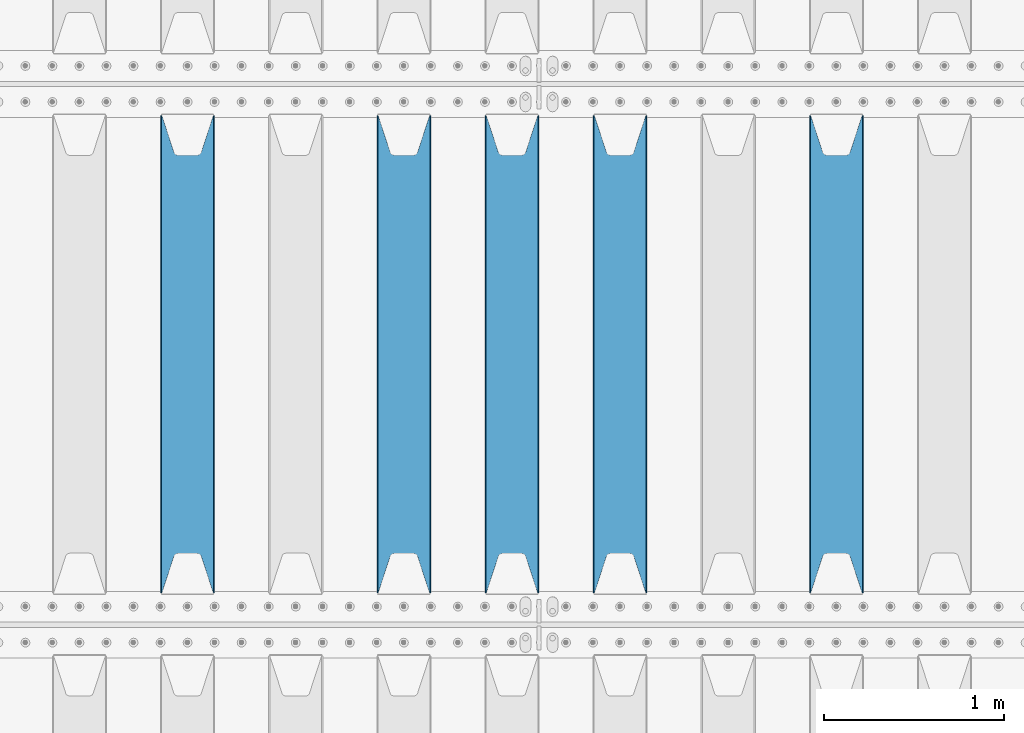
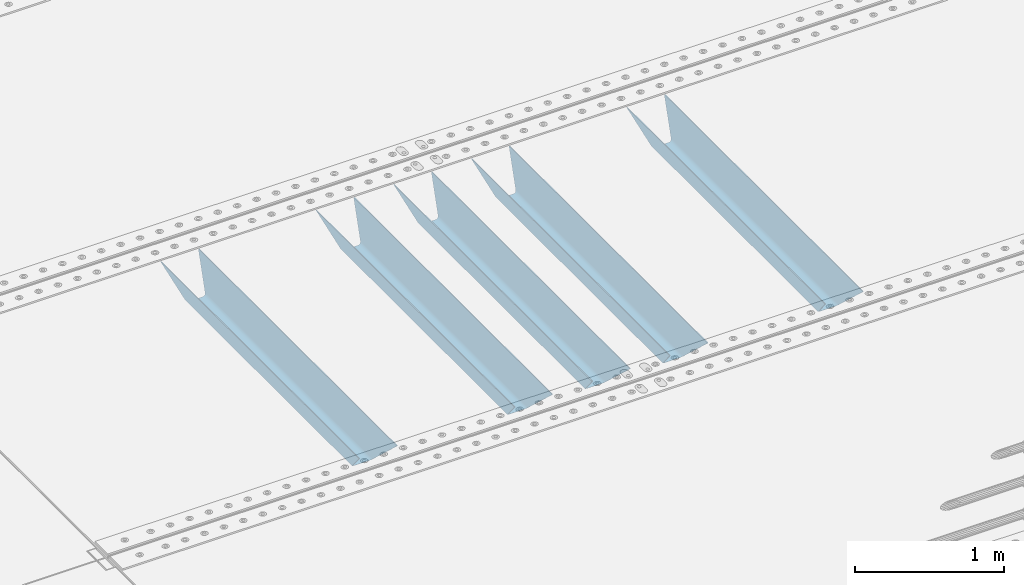
# One storey, part 103 of 240: 5 beams.
"""IFC2X3 building model written with IfcOpenShell, lengths in millimetres."""

from ifc_helpers import new_model, si_unit, frame, origin_with_axes, place, context, subcontext, project, spatial, faceted_brep, material, type_object, element, save


model = new_model("IFC2X3")

# Units and contexts
model_context = context("Model", 3, precision=1e-05, world=origin_with_axes())
body_context = subcontext(model_context, "Body", "Model", "MODEL_VIEW")
ifc_project = project(units=[si_unit("LENGTHUNIT", "METRE", prefix="MILLI"), si_unit("AREAUNIT", "SQUARE_METRE"), si_unit("VOLUMEUNIT", "CUBIC_METRE"), si_unit("MASSUNIT", "GRAM", prefix="KILO"), si_unit("TIMEUNIT", "SECOND"), si_unit("PLANEANGLEUNIT", "RADIAN"), si_unit("SOLIDANGLEUNIT", "STERADIAN"), si_unit("THERMODYNAMICTEMPERATUREUNIT", "DEGREE_CELSIUS"), si_unit("LUMINOUSINTENSITYUNIT", "LUMEN")], contexts=[model_context])

# Site, building, storey
site_placement = place(None, origin_with_axes())
site = spatial("IfcSite", under=ifc_project, at=site_placement, CompositionType="ELEMENT")
building_placement = place(site_placement, origin_with_axes())
building = spatial("IfcBuilding", under=site, at=building_placement, Name="Standard", CompositionType="ELEMENT")
storey_placement = place(building_placement, origin_with_axes())
storey = spatial("IfcBuildingStorey", under=building, at=storey_placement, Name="Undefined", CompositionType="ELEMENT", Elevation=0.0)

# Beams
ifc_material = material(Name="STEEL/S355N")
beam_type = type_object("IfcBeamType", PredefinedType="NOTDEFINED")
beam_1_placement = place(storey_placement, frame((48250.0, 27175.0, -115.0), z_axis=(0.0, 0.0, 1.0), x_axis=(0.0, 1.0, 0.0)))
element("IfcBeam", 1, at=beam_1_placement, inside=storey, type_object=beam_type, material=ifc_material, context=body_context, shape_type="Brep", body=[
    faceted_brep([(0.0, 150.0, 115.0), (0.0, 143.690000000002, 115.0), (2650.00000000297, 143.690000000002, 115.0), (2650.00000000297, 150.0, 115.0), (2650.00000000297, 142.059565218406, 110.000000003094), (2650.00000000297, 148.369565218403, 110.000000003094), (2441.90079219209, -80.1103600731149, -98.0992078077845), (2437.7588105432, -77.5672621345584, -102.241189456673), (2434.06523489747, -74.4080125315522, -105.934765102404), (2430.9108609509, -70.7102721255724, -109.089139048974), (2428.37322971128, -66.5649389910031, -111.626770288588), (2426.51472138055, -62.0739139532889, -113.485278619323), (2425.38102192092, -57.3475956567636, -114.618978078955), (2424.99999999987, -52.5021667386536, -115.0), (2424.99999999987, 52.5021667386536, -115.0), (2425.38102192092, 57.3475956567636, -114.618978078955), (2426.51472138055, 62.0739139532889, -113.485278619323), (2428.37322971128, 66.5649389910031, -111.626770288588), (2430.9108609509, 70.7102721255724, -109.089139048974), (2434.06523489747, 74.4080125315522, -105.934765102404), (2437.7588105432, 77.5672621345584, -102.241189456673), (2441.90079219209, 80.1103600731149, -98.0992078077846), (2446.38936140512, 81.9747917625791, -93.6106385947584), (2448.2494850041, 76.2713538057287, -91.7505149957729), (2444.62967112263, 74.76777986261, -95.3703288772456), (2441.28936334127, 72.7168944282894, -98.710636658607), (2438.31067330439, 70.1691124903809, -101.689326695487), (2435.76682334748, 67.1870637758839, -104.233176652398), (2433.72034654134, 63.8440531834931, -106.279653458539), (2432.22154950042, 60.2222587982324, -107.778450499454), (2431.30727574265, 56.4107117849126, -108.692724257221), (2430.99999999987, 52.5031078186876, -109.0), (2430.99999999987, -52.5031078186876, -109.0), (2431.30727574265, -56.4107117849126, -108.692724257221), (2432.22154950042, -60.2222587982324, -107.778450499454), (2433.72034654134, -63.8440531834931, -106.279653458539), (2435.76682334748, -67.1870637758839, -104.233176652398), (2438.31067330439, -70.1691124903809, -101.689326695487), (2441.28936334127, -72.7168944282894, -98.7106366586071), (2444.62967112263, -74.76777986261, -95.3703288772457), (2448.2494850041, -76.2713538057287, -91.7505149957729), (2650.00000000297, -142.059565218406, 110.000000003094), (2650.00000000297, -148.369565218403, 110.000000003094), (2446.38936140512, -81.9747917625791, -93.6106385947584), (2650.00000000297, -143.690000000002, 115.0), (2650.00000000297, -150.0, 115.0), (0.0, -143.690000000002, 115.0), (0.0, -150.0, 115.0), (0.0, -148.369565218258, 110.000000002667), (203.610638597427, -81.9747917625791, -93.6106385947584), (208.09920781045, -80.1103600731149, -98.0992078077845), (212.241189459342, -77.5672621345584, -102.241189456673), (215.93476510507, -74.4080125315522, -105.934765102404), (219.089139051641, -70.7102721255724, -109.089139048974), (221.626770291256, -66.5649389910031, -111.626770288588), (223.485278621989, -62.0739139532889, -113.485278619323), (224.618978081624, -57.3475956567636, -114.618978078955), (225.000000002663, -52.5021667386536, -115.0), (225.000000002663, 52.5021667386536, -115.0), (224.618978081624, 57.3475956567636, -114.618978078955), (223.485278621989, 62.0739139532889, -113.485278619323), (221.626770291256, 66.5649389910031, -111.626770288588), (219.089139051641, 70.7102721255724, -109.089139048974), (215.93476510507, 74.4080125315522, -105.934765102404), (212.241189459342, 77.5672621345584, -102.241189456673), (208.09920781045, 80.1103600731149, -98.0992078077846), (203.610638597427, 81.9747917625791, -93.6106385947584), (0.0, 148.369565218258, 110.000000002667), (0.0, 142.05956521826, 110.000000002667), (201.750514998439, 76.2713538057287, -91.7505149957729), (205.370328879908, 74.76777986261, -95.3703288772456), (208.710636661275, 72.7168944282894, -98.710636658607), (211.689326698153, 70.1691124903809, -101.689326695487), (214.233176655063, 67.1870637758839, -104.233176652398), (216.279653461206, 63.8440531834931, -106.279653458539), (217.778450502123, 60.2222587982324, -107.778450499454), (218.692724259887, 56.4107117849126, -108.692724257221), (219.000000002667, 52.5031078186876, -109.0), (219.000000002667, -52.5031078186876, -109.0), (218.692724259887, -56.4107117849126, -108.692724257221), (217.778450502123, -60.2222587982324, -107.778450499454), (216.279653461206, -63.8440531834931, -106.279653458539), (214.233176655063, -67.1870637758839, -104.233176652398), (211.689326698153, -70.1691124903809, -101.689326695487), (208.710636661275, -72.7168944282894, -98.7106366586071), (205.370328879915, -74.76777986261, -95.3703288772457), (201.750514998439, -76.2713538057287, -91.7505149957729), (0.0, -142.05956521826, 110.000000002667)], [[[0, 1, 2, 3]], [[3, 2, 4, 5]], [[6, 7, 8, 9, 10, 11, 12, 13, 14, 15, 16, 17, 18, 19, 20, 21, 22, 5, 4, 23, 24, 25, 26, 27, 28, 29, 30, 31, 32, 33, 34, 35, 36, 37, 38, 39, 40, 41, 42, 43]], [[44, 45, 42, 41]], [[46, 47, 45, 44]], [[43, 42, 45, 47, 48, 49]], [[6, 43, 49, 50]], [[7, 6, 50, 51]], [[8, 7, 51, 52]], [[9, 8, 52, 53]], [[10, 9, 53, 54]], [[11, 10, 54, 55]], [[12, 11, 55, 56]], [[13, 12, 56, 57]], [[14, 13, 57, 58]], [[15, 14, 58, 59]], [[16, 15, 59, 60]], [[17, 16, 60, 61]], [[18, 17, 61, 62]], [[19, 18, 62, 63]], [[20, 19, 63, 64]], [[21, 20, 64, 65]], [[22, 21, 65, 66]], [[0, 3, 5, 22, 66, 67]], [[1, 0, 67, 68]], [[23, 4, 2, 1, 68, 69]], [[24, 23, 69, 70]], [[25, 24, 70, 71]], [[26, 25, 71, 72]], [[27, 26, 72, 73]], [[28, 27, 73, 74]], [[29, 28, 74, 75]], [[30, 29, 75, 76]], [[31, 30, 76, 77]], [[32, 31, 77, 78]], [[33, 32, 78, 79]], [[34, 33, 79, 80]], [[35, 34, 80, 81]], [[36, 35, 81, 82]], [[37, 36, 82, 83]], [[38, 37, 83, 84]], [[39, 38, 84, 85]], [[40, 39, 85, 86]], [[46, 44, 41, 40, 86, 87]], [[47, 46, 87, 48]], [[86, 85, 84, 83, 82, 81, 80, 79, 78, 77, 76, 75, 74, 73, 72, 71, 70, 69, 68, 67, 66, 65, 64, 63, 62, 61, 60, 59, 58, 57, 56, 55, 54, 53, 52, 51, 50, 49, 48, 87]]]),
])
beam_2_placement = place(storey_placement, frame((47050.0, 27175.0, -115.0), z_axis=(0.0, 0.0, 1.0), x_axis=(0.0, 1.0, 0.0)))
element("IfcBeam", 2, at=beam_2_placement, inside=storey, type_object=beam_type, material=ifc_material, context=body_context, shape_type="Brep", body=[
    faceted_brep([(0.0, 150.0, 115.0), (0.0, 143.690000000002, 115.0), (2650.00000000297, 143.690000000002, 115.0), (2650.00000000297, 150.0, 115.0), (2650.00000000297, 142.059565218406, 110.000000003094), (2650.00000000297, 148.369565218403, 110.000000003094), (2441.90079219209, -80.1103600731149, -98.0992078077845), (2437.7588105432, -77.5672621345584, -102.241189456673), (2434.06523489747, -74.4080125315522, -105.934765102404), (2430.9108609509, -70.7102721255724, -109.089139048974), (2428.37322971128, -66.5649389910031, -111.626770288588), (2426.51472138055, -62.0739139532889, -113.485278619323), (2425.38102192092, -57.3475956567636, -114.618978078955), (2424.99999999987, -52.5021667386536, -115.0), (2424.99999999987, 52.5021667386536, -115.0), (2425.38102192092, 57.3475956567636, -114.618978078955), (2426.51472138055, 62.0739139532889, -113.485278619323), (2428.37322971128, 66.5649389910031, -111.626770288588), (2430.9108609509, 70.7102721255724, -109.089139048974), (2434.06523489747, 74.4080125315522, -105.934765102404), (2437.7588105432, 77.5672621345584, -102.241189456673), (2441.90079219209, 80.1103600731149, -98.0992078077846), (2446.38936140512, 81.9747917625791, -93.6106385947584), (2448.2494850041, 76.2713538057287, -91.7505149957729), (2444.62967112263, 74.76777986261, -95.3703288772456), (2441.28936334127, 72.7168944282894, -98.710636658607), (2438.31067330439, 70.1691124903809, -101.689326695487), (2435.76682334748, 67.1870637758839, -104.233176652398), (2433.72034654134, 63.8440531834931, -106.279653458539), (2432.22154950042, 60.2222587982324, -107.778450499454), (2431.30727574265, 56.4107117849126, -108.692724257221), (2430.99999999987, 52.5031078186876, -109.0), (2430.99999999987, -52.5031078186876, -109.0), (2431.30727574265, -56.4107117849126, -108.692724257221), (2432.22154950042, -60.2222587982324, -107.778450499454), (2433.72034654134, -63.8440531834931, -106.279653458539), (2435.76682334748, -67.1870637758839, -104.233176652398), (2438.31067330439, -70.1691124903809, -101.689326695487), (2441.28936334127, -72.7168944282894, -98.7106366586071), (2444.62967112263, -74.76777986261, -95.3703288772457), (2448.2494850041, -76.2713538057287, -91.7505149957729), (2650.00000000297, -142.059565218406, 110.000000003094), (2650.00000000297, -148.369565218403, 110.000000003094), (2446.38936140512, -81.9747917625791, -93.6106385947584), (2650.00000000297, -143.690000000002, 115.0), (2650.00000000297, -150.0, 115.0), (0.0, -143.690000000002, 115.0), (0.0, -150.0, 115.0), (0.0, -148.369565218258, 110.000000002667), (203.610638597427, -81.9747917625791, -93.6106385947584), (208.09920781045, -80.1103600731149, -98.0992078077845), (212.241189459342, -77.5672621345584, -102.241189456673), (215.93476510507, -74.4080125315522, -105.934765102404), (219.089139051641, -70.7102721255724, -109.089139048974), (221.626770291256, -66.5649389910031, -111.626770288588), (223.485278621989, -62.0739139532889, -113.485278619323), (224.618978081624, -57.3475956567636, -114.618978078955), (225.000000002663, -52.5021667386536, -115.0), (225.000000002663, 52.5021667386536, -115.0), (224.618978081624, 57.3475956567636, -114.618978078955), (223.485278621989, 62.0739139532889, -113.485278619323), (221.626770291256, 66.5649389910031, -111.626770288588), (219.089139051641, 70.7102721255724, -109.089139048974), (215.93476510507, 74.4080125315522, -105.934765102404), (212.241189459342, 77.5672621345584, -102.241189456673), (208.09920781045, 80.1103600731149, -98.0992078077846), (203.610638597427, 81.9747917625791, -93.6106385947584), (0.0, 148.369565218258, 110.000000002667), (0.0, 142.05956521826, 110.000000002667), (201.750514998439, 76.2713538057287, -91.7505149957729), (205.370328879908, 74.76777986261, -95.3703288772456), (208.710636661275, 72.7168944282894, -98.710636658607), (211.689326698153, 70.1691124903809, -101.689326695487), (214.233176655063, 67.1870637758839, -104.233176652398), (216.279653461206, 63.8440531834931, -106.279653458539), (217.778450502123, 60.2222587982324, -107.778450499454), (218.692724259887, 56.4107117849126, -108.692724257221), (219.000000002667, 52.5031078186876, -109.0), (219.000000002667, -52.5031078186876, -109.0), (218.692724259887, -56.4107117849126, -108.692724257221), (217.778450502123, -60.2222587982324, -107.778450499454), (216.279653461206, -63.8440531834931, -106.279653458539), (214.233176655063, -67.1870637758839, -104.233176652398), (211.689326698153, -70.1691124903809, -101.689326695487), (208.710636661275, -72.7168944282894, -98.7106366586071), (205.370328879915, -74.76777986261, -95.3703288772457), (201.750514998439, -76.2713538057287, -91.7505149957729), (0.0, -142.05956521826, 110.000000002667)], [[[0, 1, 2, 3]], [[3, 2, 4, 5]], [[6, 7, 8, 9, 10, 11, 12, 13, 14, 15, 16, 17, 18, 19, 20, 21, 22, 5, 4, 23, 24, 25, 26, 27, 28, 29, 30, 31, 32, 33, 34, 35, 36, 37, 38, 39, 40, 41, 42, 43]], [[44, 45, 42, 41]], [[46, 47, 45, 44]], [[43, 42, 45, 47, 48, 49]], [[6, 43, 49, 50]], [[7, 6, 50, 51]], [[8, 7, 51, 52]], [[9, 8, 52, 53]], [[10, 9, 53, 54]], [[11, 10, 54, 55]], [[12, 11, 55, 56]], [[13, 12, 56, 57]], [[14, 13, 57, 58]], [[15, 14, 58, 59]], [[16, 15, 59, 60]], [[17, 16, 60, 61]], [[18, 17, 61, 62]], [[19, 18, 62, 63]], [[20, 19, 63, 64]], [[21, 20, 64, 65]], [[22, 21, 65, 66]], [[0, 3, 5, 22, 66, 67]], [[1, 0, 67, 68]], [[23, 4, 2, 1, 68, 69]], [[24, 23, 69, 70]], [[25, 24, 70, 71]], [[26, 25, 71, 72]], [[27, 26, 72, 73]], [[28, 27, 73, 74]], [[29, 28, 74, 75]], [[30, 29, 75, 76]], [[31, 30, 76, 77]], [[32, 31, 77, 78]], [[33, 32, 78, 79]], [[34, 33, 79, 80]], [[35, 34, 80, 81]], [[36, 35, 81, 82]], [[37, 36, 82, 83]], [[38, 37, 83, 84]], [[39, 38, 84, 85]], [[40, 39, 85, 86]], [[46, 44, 41, 40, 86, 87]], [[47, 46, 87, 48]], [[86, 85, 84, 83, 82, 81, 80, 79, 78, 77, 76, 75, 74, 73, 72, 71, 70, 69, 68, 67, 66, 65, 64, 63, 62, 61, 60, 59, 58, 57, 56, 55, 54, 53, 52, 51, 50, 49, 48, 87]]]),
])
beam_3_placement = place(storey_placement, frame((46450.0, 27175.0, -115.0), z_axis=(0.0, 0.0, 1.0), x_axis=(0.0, 1.0, 0.0)))
element("IfcBeam", 3, at=beam_3_placement, inside=storey, type_object=beam_type, material=ifc_material, context=body_context, shape_type="Brep", body=[
    faceted_brep([(0.0, 150.0, 115.0), (0.0, 143.690000000002, 115.0), (2650.00000000297, 143.690000000002, 115.0), (2650.00000000297, 150.0, 115.0), (2650.00000000297, 142.059565218406, 110.000000003094), (2650.00000000297, 148.369565218403, 110.000000003094), (2441.90079219209, -80.1103600731149, -98.0992078077845), (2437.7588105432, -77.5672621345584, -102.241189456673), (2434.06523489747, -74.4080125315522, -105.934765102404), (2430.9108609509, -70.7102721255724, -109.089139048974), (2428.37322971128, -66.5649389910031, -111.626770288588), (2426.51472138055, -62.0739139532889, -113.485278619323), (2425.38102192092, -57.3475956567636, -114.618978078955), (2424.99999999987, -52.5021667386536, -115.0), (2424.99999999987, 52.5021667386536, -115.0), (2425.38102192092, 57.3475956567636, -114.618978078955), (2426.51472138055, 62.0739139532889, -113.485278619323), (2428.37322971128, 66.5649389910031, -111.626770288588), (2430.9108609509, 70.7102721255724, -109.089139048974), (2434.06523489747, 74.4080125315522, -105.934765102404), (2437.7588105432, 77.5672621345584, -102.241189456673), (2441.90079219209, 80.1103600731149, -98.0992078077846), (2446.38936140512, 81.9747917625791, -93.6106385947584), (2448.2494850041, 76.2713538057287, -91.7505149957729), (2444.62967112263, 74.76777986261, -95.3703288772456), (2441.28936334127, 72.7168944282894, -98.710636658607), (2438.31067330439, 70.1691124903809, -101.689326695487), (2435.76682334748, 67.1870637758839, -104.233176652398), (2433.72034654134, 63.8440531834931, -106.279653458539), (2432.22154950042, 60.2222587982324, -107.778450499454), (2431.30727574265, 56.4107117849126, -108.692724257221), (2430.99999999987, 52.5031078186876, -109.0), (2430.99999999987, -52.5031078186876, -109.0), (2431.30727574265, -56.4107117849126, -108.692724257221), (2432.22154950042, -60.2222587982324, -107.778450499454), (2433.72034654134, -63.8440531834931, -106.279653458539), (2435.76682334748, -67.1870637758839, -104.233176652398), (2438.31067330439, -70.1691124903809, -101.689326695487), (2441.28936334127, -72.7168944282894, -98.7106366586071), (2444.62967112263, -74.76777986261, -95.3703288772457), (2448.2494850041, -76.2713538057287, -91.7505149957729), (2650.00000000297, -142.059565218406, 110.000000003094), (2650.00000000297, -148.369565218403, 110.000000003094), (2446.38936140512, -81.9747917625791, -93.6106385947584), (2650.00000000297, -143.690000000002, 115.0), (2650.00000000297, -150.0, 115.0), (0.0, -143.690000000002, 115.0), (0.0, -150.0, 115.0), (0.0, -148.369565218258, 110.000000002667), (203.610638597427, -81.9747917625791, -93.6106385947584), (208.09920781045, -80.1103600731149, -98.0992078077845), (212.241189459342, -77.5672621345584, -102.241189456673), (215.93476510507, -74.4080125315522, -105.934765102404), (219.089139051641, -70.7102721255724, -109.089139048974), (221.626770291256, -66.5649389910031, -111.626770288588), (223.485278621989, -62.0739139532889, -113.485278619323), (224.618978081624, -57.3475956567636, -114.618978078955), (225.000000002663, -52.5021667386536, -115.0), (225.000000002663, 52.5021667386536, -115.0), (224.618978081624, 57.3475956567636, -114.618978078955), (223.485278621989, 62.0739139532889, -113.485278619323), (221.626770291256, 66.5649389910031, -111.626770288588), (219.089139051641, 70.7102721255724, -109.089139048974), (215.93476510507, 74.4080125315522, -105.934765102404), (212.241189459342, 77.5672621345584, -102.241189456673), (208.09920781045, 80.1103600731149, -98.0992078077846), (203.610638597427, 81.9747917625791, -93.6106385947584), (0.0, 148.369565218258, 110.000000002667), (0.0, 142.05956521826, 110.000000002667), (201.750514998439, 76.2713538057287, -91.7505149957729), (205.370328879908, 74.76777986261, -95.3703288772456), (208.710636661275, 72.7168944282894, -98.710636658607), (211.689326698153, 70.1691124903809, -101.689326695487), (214.233176655063, 67.1870637758839, -104.233176652398), (216.279653461206, 63.8440531834931, -106.279653458539), (217.778450502123, 60.2222587982324, -107.778450499454), (218.692724259887, 56.4107117849126, -108.692724257221), (219.000000002667, 52.5031078186876, -109.0), (219.000000002667, -52.5031078186876, -109.0), (218.692724259887, -56.4107117849126, -108.692724257221), (217.778450502123, -60.2222587982324, -107.778450499454), (216.279653461206, -63.8440531834931, -106.279653458539), (214.233176655063, -67.1870637758839, -104.233176652398), (211.689326698153, -70.1691124903809, -101.689326695487), (208.710636661275, -72.7168944282894, -98.7106366586071), (205.370328879915, -74.76777986261, -95.3703288772457), (201.750514998439, -76.2713538057287, -91.7505149957729), (0.0, -142.05956521826, 110.000000002667)], [[[0, 1, 2, 3]], [[3, 2, 4, 5]], [[6, 7, 8, 9, 10, 11, 12, 13, 14, 15, 16, 17, 18, 19, 20, 21, 22, 5, 4, 23, 24, 25, 26, 27, 28, 29, 30, 31, 32, 33, 34, 35, 36, 37, 38, 39, 40, 41, 42, 43]], [[44, 45, 42, 41]], [[46, 47, 45, 44]], [[43, 42, 45, 47, 48, 49]], [[6, 43, 49, 50]], [[7, 6, 50, 51]], [[8, 7, 51, 52]], [[9, 8, 52, 53]], [[10, 9, 53, 54]], [[11, 10, 54, 55]], [[12, 11, 55, 56]], [[13, 12, 56, 57]], [[14, 13, 57, 58]], [[15, 14, 58, 59]], [[16, 15, 59, 60]], [[17, 16, 60, 61]], [[18, 17, 61, 62]], [[19, 18, 62, 63]], [[20, 19, 63, 64]], [[21, 20, 64, 65]], [[22, 21, 65, 66]], [[0, 3, 5, 22, 66, 67]], [[1, 0, 67, 68]], [[23, 4, 2, 1, 68, 69]], [[24, 23, 69, 70]], [[25, 24, 70, 71]], [[26, 25, 71, 72]], [[27, 26, 72, 73]], [[28, 27, 73, 74]], [[29, 28, 74, 75]], [[30, 29, 75, 76]], [[31, 30, 76, 77]], [[32, 31, 77, 78]], [[33, 32, 78, 79]], [[34, 33, 79, 80]], [[35, 34, 80, 81]], [[36, 35, 81, 82]], [[37, 36, 82, 83]], [[38, 37, 83, 84]], [[39, 38, 84, 85]], [[40, 39, 85, 86]], [[46, 44, 41, 40, 86, 87]], [[47, 46, 87, 48]], [[86, 85, 84, 83, 82, 81, 80, 79, 78, 77, 76, 75, 74, 73, 72, 71, 70, 69, 68, 67, 66, 65, 64, 63, 62, 61, 60, 59, 58, 57, 56, 55, 54, 53, 52, 51, 50, 49, 48, 87]]]),
])
beam_4_placement = place(storey_placement, frame((45850.0, 27175.0, -115.0), z_axis=(0.0, 0.0, 1.0), x_axis=(0.0, 1.0, 0.0)))
element("IfcBeam", 4, at=beam_4_placement, inside=storey, type_object=beam_type, material=ifc_material, context=body_context, shape_type="Brep", body=[
    faceted_brep([(0.0, 150.0, 115.0), (0.0, 143.690000000002, 115.0), (2650.00000000297, 143.690000000002, 115.0), (2650.00000000297, 150.0, 115.0), (2650.00000000297, 142.059565218406, 110.000000003094), (2650.00000000297, 148.369565218403, 110.000000003094), (2441.90079219209, -80.1103600731149, -98.0992078077845), (2437.7588105432, -77.5672621345584, -102.241189456673), (2434.06523489747, -74.4080125315522, -105.934765102404), (2430.9108609509, -70.7102721255724, -109.089139048974), (2428.37322971128, -66.5649389910031, -111.626770288588), (2426.51472138055, -62.0739139532889, -113.485278619323), (2425.38102192092, -57.3475956567636, -114.618978078955), (2424.99999999987, -52.5021667386536, -115.0), (2424.99999999987, 52.5021667386536, -115.0), (2425.38102192092, 57.3475956567636, -114.618978078955), (2426.51472138055, 62.0739139532889, -113.485278619323), (2428.37322971128, 66.5649389910031, -111.626770288588), (2430.9108609509, 70.7102721255724, -109.089139048974), (2434.06523489747, 74.4080125315522, -105.934765102404), (2437.7588105432, 77.5672621345584, -102.241189456673), (2441.90079219209, 80.1103600731149, -98.0992078077846), (2446.38936140512, 81.9747917625791, -93.6106385947584), (2448.2494850041, 76.2713538057287, -91.7505149957729), (2444.62967112263, 74.76777986261, -95.3703288772456), (2441.28936334127, 72.7168944282894, -98.710636658607), (2438.31067330439, 70.1691124903809, -101.689326695487), (2435.76682334748, 67.1870637758839, -104.233176652398), (2433.72034654134, 63.8440531834931, -106.279653458539), (2432.22154950042, 60.2222587982324, -107.778450499454), (2431.30727574265, 56.4107117849126, -108.692724257221), (2430.99999999987, 52.5031078186876, -109.0), (2430.99999999987, -52.5031078186876, -109.0), (2431.30727574265, -56.4107117849126, -108.692724257221), (2432.22154950042, -60.2222587982324, -107.778450499454), (2433.72034654134, -63.8440531834931, -106.279653458539), (2435.76682334748, -67.1870637758839, -104.233176652398), (2438.31067330439, -70.1691124903809, -101.689326695487), (2441.28936334127, -72.7168944282894, -98.7106366586071), (2444.62967112263, -74.76777986261, -95.3703288772457), (2448.2494850041, -76.2713538057287, -91.7505149957729), (2650.00000000297, -142.059565218406, 110.000000003094), (2650.00000000297, -148.369565218403, 110.000000003094), (2446.38936140512, -81.9747917625791, -93.6106385947584), (2650.00000000297, -143.690000000002, 115.0), (2650.00000000297, -150.0, 115.0), (0.0, -143.690000000002, 115.0), (0.0, -150.0, 115.0), (0.0, -148.369565218258, 110.000000002667), (203.610638597427, -81.9747917625791, -93.6106385947584), (208.09920781045, -80.1103600731149, -98.0992078077845), (212.241189459342, -77.5672621345584, -102.241189456673), (215.93476510507, -74.4080125315522, -105.934765102404), (219.089139051641, -70.7102721255724, -109.089139048974), (221.626770291256, -66.5649389910031, -111.626770288588), (223.485278621989, -62.0739139532889, -113.485278619323), (224.618978081624, -57.3475956567636, -114.618978078955), (225.000000002663, -52.5021667386536, -115.0), (225.000000002663, 52.5021667386536, -115.0), (224.618978081624, 57.3475956567636, -114.618978078955), (223.485278621989, 62.0739139532889, -113.485278619323), (221.626770291256, 66.5649389910031, -111.626770288588), (219.089139051641, 70.7102721255724, -109.089139048974), (215.93476510507, 74.4080125315522, -105.934765102404), (212.241189459342, 77.5672621345584, -102.241189456673), (208.09920781045, 80.1103600731149, -98.0992078077846), (203.610638597427, 81.9747917625791, -93.6106385947584), (0.0, 148.369565218258, 110.000000002667), (0.0, 142.05956521826, 110.000000002667), (201.750514998439, 76.2713538057287, -91.7505149957729), (205.370328879908, 74.76777986261, -95.3703288772456), (208.710636661275, 72.7168944282894, -98.710636658607), (211.689326698153, 70.1691124903809, -101.689326695487), (214.233176655063, 67.1870637758839, -104.233176652398), (216.279653461206, 63.8440531834931, -106.279653458539), (217.778450502123, 60.2222587982324, -107.778450499454), (218.692724259887, 56.4107117849126, -108.692724257221), (219.000000002667, 52.5031078186876, -109.0), (219.000000002667, -52.5031078186876, -109.0), (218.692724259887, -56.4107117849126, -108.692724257221), (217.778450502123, -60.2222587982324, -107.778450499454), (216.279653461206, -63.8440531834931, -106.279653458539), (214.233176655063, -67.1870637758839, -104.233176652398), (211.689326698153, -70.1691124903809, -101.689326695487), (208.710636661275, -72.7168944282894, -98.7106366586071), (205.370328879915, -74.76777986261, -95.3703288772457), (201.750514998439, -76.2713538057287, -91.7505149957729), (0.0, -142.05956521826, 110.000000002667)], [[[0, 1, 2, 3]], [[3, 2, 4, 5]], [[6, 7, 8, 9, 10, 11, 12, 13, 14, 15, 16, 17, 18, 19, 20, 21, 22, 5, 4, 23, 24, 25, 26, 27, 28, 29, 30, 31, 32, 33, 34, 35, 36, 37, 38, 39, 40, 41, 42, 43]], [[44, 45, 42, 41]], [[46, 47, 45, 44]], [[43, 42, 45, 47, 48, 49]], [[6, 43, 49, 50]], [[7, 6, 50, 51]], [[8, 7, 51, 52]], [[9, 8, 52, 53]], [[10, 9, 53, 54]], [[11, 10, 54, 55]], [[12, 11, 55, 56]], [[13, 12, 56, 57]], [[14, 13, 57, 58]], [[15, 14, 58, 59]], [[16, 15, 59, 60]], [[17, 16, 60, 61]], [[18, 17, 61, 62]], [[19, 18, 62, 63]], [[20, 19, 63, 64]], [[21, 20, 64, 65]], [[22, 21, 65, 66]], [[0, 3, 5, 22, 66, 67]], [[1, 0, 67, 68]], [[23, 4, 2, 1, 68, 69]], [[24, 23, 69, 70]], [[25, 24, 70, 71]], [[26, 25, 71, 72]], [[27, 26, 72, 73]], [[28, 27, 73, 74]], [[29, 28, 74, 75]], [[30, 29, 75, 76]], [[31, 30, 76, 77]], [[32, 31, 77, 78]], [[33, 32, 78, 79]], [[34, 33, 79, 80]], [[35, 34, 80, 81]], [[36, 35, 81, 82]], [[37, 36, 82, 83]], [[38, 37, 83, 84]], [[39, 38, 84, 85]], [[40, 39, 85, 86]], [[46, 44, 41, 40, 86, 87]], [[47, 46, 87, 48]], [[86, 85, 84, 83, 82, 81, 80, 79, 78, 77, 76, 75, 74, 73, 72, 71, 70, 69, 68, 67, 66, 65, 64, 63, 62, 61, 60, 59, 58, 57, 56, 55, 54, 53, 52, 51, 50, 49, 48, 87]]]),
])
beam_5_placement = place(storey_placement, frame((44650.0, 27175.0, -115.0), z_axis=(0.0, 0.0, 1.0), x_axis=(0.0, 1.0, 0.0)))
element("IfcBeam", 5, at=beam_5_placement, inside=storey, type_object=beam_type, material=ifc_material, context=body_context, shape_type="Brep", body=[
    faceted_brep([(0.0, 150.0, 115.0), (0.0, 143.690000000002, 115.0), (2650.00000000297, 143.690000000002, 115.0), (2650.00000000297, 150.0, 115.0), (2650.00000000297, 142.059565218406, 110.000000003094), (2650.00000000297, 148.369565218403, 110.000000003094), (2441.90079219209, -80.1103600731149, -98.0992078077845), (2437.7588105432, -77.5672621345584, -102.241189456673), (2434.06523489747, -74.4080125315522, -105.934765102404), (2430.9108609509, -70.7102721255724, -109.089139048974), (2428.37322971128, -66.5649389910031, -111.626770288588), (2426.51472138055, -62.0739139532889, -113.485278619323), (2425.38102192092, -57.3475956567636, -114.618978078955), (2424.99999999987, -52.5021667386536, -115.0), (2424.99999999987, 52.5021667386536, -115.0), (2425.38102192092, 57.3475956567636, -114.618978078955), (2426.51472138055, 62.0739139532889, -113.485278619323), (2428.37322971128, 66.5649389910031, -111.626770288588), (2430.9108609509, 70.7102721255724, -109.089139048974), (2434.06523489747, 74.4080125315522, -105.934765102404), (2437.7588105432, 77.5672621345584, -102.241189456673), (2441.90079219209, 80.1103600731149, -98.0992078077846), (2446.38936140512, 81.9747917625791, -93.6106385947584), (2448.2494850041, 76.2713538057287, -91.7505149957729), (2444.62967112263, 74.76777986261, -95.3703288772456), (2441.28936334127, 72.7168944282894, -98.710636658607), (2438.31067330439, 70.1691124903809, -101.689326695487), (2435.76682334748, 67.1870637758839, -104.233176652398), (2433.72034654134, 63.8440531834931, -106.279653458539), (2432.22154950042, 60.2222587982324, -107.778450499454), (2431.30727574265, 56.4107117849126, -108.692724257221), (2430.99999999987, 52.5031078186876, -109.0), (2430.99999999987, -52.5031078186876, -109.0), (2431.30727574265, -56.4107117849126, -108.692724257221), (2432.22154950042, -60.2222587982324, -107.778450499454), (2433.72034654134, -63.8440531834931, -106.279653458539), (2435.76682334748, -67.1870637758839, -104.233176652398), (2438.31067330439, -70.1691124903809, -101.689326695487), (2441.28936334127, -72.7168944282894, -98.7106366586071), (2444.62967112263, -74.76777986261, -95.3703288772457), (2448.2494850041, -76.2713538057287, -91.7505149957729), (2650.00000000297, -142.059565218406, 110.000000003094), (2650.00000000297, -148.369565218403, 110.000000003094), (2446.38936140512, -81.9747917625791, -93.6106385947584), (2650.00000000297, -143.690000000002, 115.0), (2650.00000000297, -150.0, 115.0), (0.0, -143.690000000002, 115.0), (0.0, -150.0, 115.0), (0.0, -148.369565218258, 110.000000002667), (203.610638597427, -81.9747917625791, -93.6106385947584), (208.09920781045, -80.1103600731149, -98.0992078077845), (212.241189459342, -77.5672621345584, -102.241189456673), (215.93476510507, -74.4080125315522, -105.934765102404), (219.089139051641, -70.7102721255724, -109.089139048974), (221.626770291256, -66.5649389910031, -111.626770288588), (223.485278621989, -62.0739139532889, -113.485278619323), (224.618978081624, -57.3475956567636, -114.618978078955), (225.000000002663, -52.5021667386536, -115.0), (225.000000002663, 52.5021667386536, -115.0), (224.618978081624, 57.3475956567636, -114.618978078955), (223.485278621989, 62.0739139532889, -113.485278619323), (221.626770291256, 66.5649389910031, -111.626770288588), (219.089139051641, 70.7102721255724, -109.089139048974), (215.93476510507, 74.4080125315522, -105.934765102404), (212.241189459342, 77.5672621345584, -102.241189456673), (208.09920781045, 80.1103600731149, -98.0992078077846), (203.610638597427, 81.9747917625791, -93.6106385947584), (0.0, 148.369565218258, 110.000000002667), (0.0, 142.05956521826, 110.000000002667), (201.750514998439, 76.2713538057287, -91.7505149957729), (205.370328879908, 74.76777986261, -95.3703288772456), (208.710636661275, 72.7168944282894, -98.710636658607), (211.689326698153, 70.1691124903809, -101.689326695487), (214.233176655063, 67.1870637758839, -104.233176652398), (216.279653461206, 63.8440531834931, -106.279653458539), (217.778450502123, 60.2222587982324, -107.778450499454), (218.692724259887, 56.4107117849126, -108.692724257221), (219.000000002667, 52.5031078186876, -109.0), (219.000000002667, -52.5031078186876, -109.0), (218.692724259887, -56.4107117849126, -108.692724257221), (217.778450502123, -60.2222587982324, -107.778450499454), (216.279653461206, -63.8440531834931, -106.279653458539), (214.233176655063, -67.1870637758839, -104.233176652398), (211.689326698153, -70.1691124903809, -101.689326695487), (208.710636661275, -72.7168944282894, -98.7106366586071), (205.370328879915, -74.76777986261, -95.3703288772457), (201.750514998439, -76.2713538057287, -91.7505149957729), (0.0, -142.05956521826, 110.000000002667)], [[[0, 1, 2, 3]], [[3, 2, 4, 5]], [[6, 7, 8, 9, 10, 11, 12, 13, 14, 15, 16, 17, 18, 19, 20, 21, 22, 5, 4, 23, 24, 25, 26, 27, 28, 29, 30, 31, 32, 33, 34, 35, 36, 37, 38, 39, 40, 41, 42, 43]], [[44, 45, 42, 41]], [[46, 47, 45, 44]], [[43, 42, 45, 47, 48, 49]], [[6, 43, 49, 50]], [[7, 6, 50, 51]], [[8, 7, 51, 52]], [[9, 8, 52, 53]], [[10, 9, 53, 54]], [[11, 10, 54, 55]], [[12, 11, 55, 56]], [[13, 12, 56, 57]], [[14, 13, 57, 58]], [[15, 14, 58, 59]], [[16, 15, 59, 60]], [[17, 16, 60, 61]], [[18, 17, 61, 62]], [[19, 18, 62, 63]], [[20, 19, 63, 64]], [[21, 20, 64, 65]], [[22, 21, 65, 66]], [[0, 3, 5, 22, 66, 67]], [[1, 0, 67, 68]], [[23, 4, 2, 1, 68, 69]], [[24, 23, 69, 70]], [[25, 24, 70, 71]], [[26, 25, 71, 72]], [[27, 26, 72, 73]], [[28, 27, 73, 74]], [[29, 28, 74, 75]], [[30, 29, 75, 76]], [[31, 30, 76, 77]], [[32, 31, 77, 78]], [[33, 32, 78, 79]], [[34, 33, 79, 80]], [[35, 34, 80, 81]], [[36, 35, 81, 82]], [[37, 36, 82, 83]], [[38, 37, 83, 84]], [[39, 38, 84, 85]], [[40, 39, 85, 86]], [[46, 44, 41, 40, 86, 87]], [[47, 46, 87, 48]], [[86, 85, 84, 83, 82, 81, 80, 79, 78, 77, 76, 75, 74, 73, 72, 71, 70, 69, 68, 67, 66, 65, 64, 63, 62, 61, 60, 59, 58, 57, 56, 55, 54, 53, 52, 51, 50, 49, 48, 87]]]),
])

save(model, "model.ifc")
